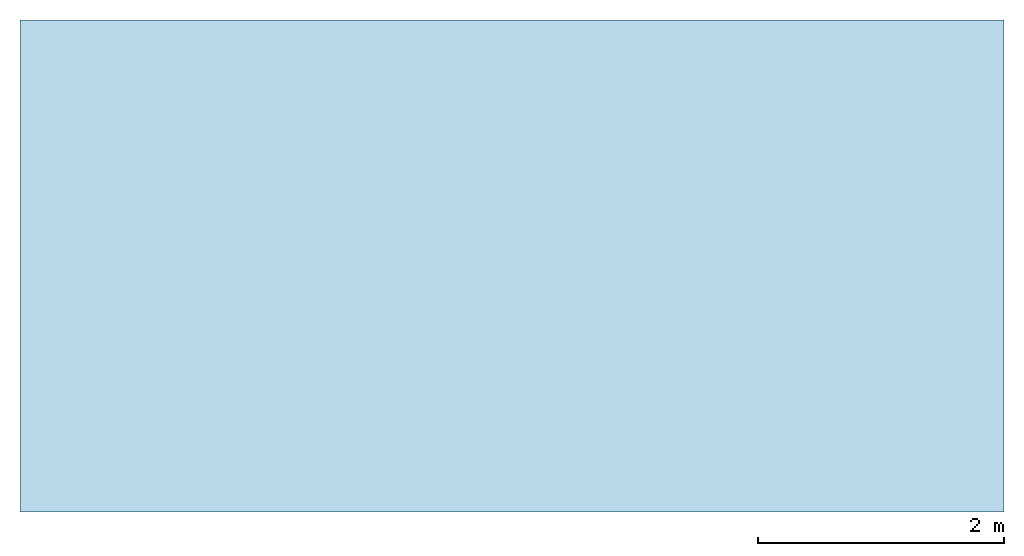
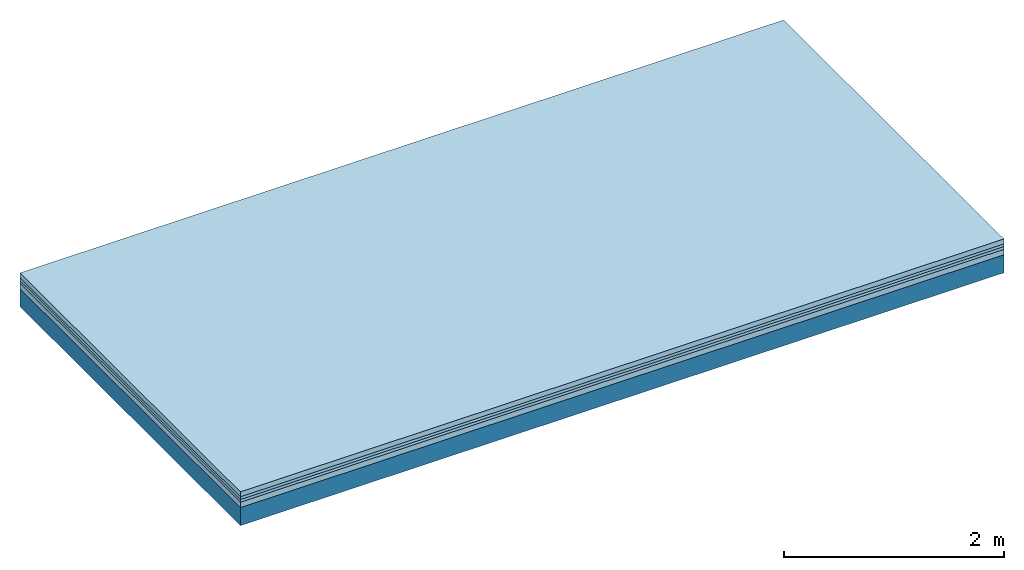
# One storey: 4 plates, 1 member, 1 element without a shape of its own.
"""IFC4 building model written with IfcOpenShell, lengths in metres."""

from ifc_helpers import new_model, si_unit, derived_unit, direction, frame, frame_2d, origin, origin_with_axes, place, context, project, spatial, rectangle, extrude, material, layer, layer_set, type_object, element, aggregate, save


model = new_model("IFC4")

# Units and contexts
plan_context = context("Plan", 3, precision=1e-05, world=origin(), true_north=direction((0.0, 1.0)))
model_context = context("Model", 3, precision=1e-05, world=origin(), true_north=direction((0.0, 1.0)))
ifc_project = project(units=[si_unit("LENGTHUNIT", "METRE"), derived_unit("SOUNDPRESSUREUNIT", [(si_unit("PRESSUREUNIT", "PASCAL", prefix="MICRO"), 0)]), si_unit("ENERGYUNIT", "JOULE", prefix="MEGA"), si_unit("MASSUNIT", "GRAM", prefix="KILO"), derived_unit("THERMALTRANSMITTANCEUNIT", [(si_unit("POWERUNIT", "WATT"), 1), (si_unit("AREAUNIT", "SQUARE_METRE"), -1), (si_unit("THERMODYNAMICTEMPERATUREUNIT", "KELVIN"), -1)]), derived_unit("AREADENSITYUNIT", [(si_unit("MASSUNIT", "GRAM", prefix="KILO"), 1), (si_unit("AREAUNIT", "SQUARE_METRE"), -1)]), derived_unit("USERDEFINED", [(si_unit("ENERGYUNIT", "JOULE", prefix="MEGA"), 1), (si_unit("AREAUNIT", "SQUARE_METRE"), -1)])], contexts=[plan_context, model_context])

# Site, building, storey
site = spatial("IfcSite", under=ifc_project)
building_placement = place(None, origin())
building = spatial("IfcBuilding", under=site, at=building_placement)
storey_placement = place(building_placement, origin())
storey = spatial("IfcBuildingStorey", under=building, at=storey_placement)

# Slab, member, plates
ifc_material_1 = material(Category="04.005")
ifc_layer_1 = layer(ifc_material_1, 0.055, Name="On-material")
ifc_material_2 = material()
ifc_layer_2 = layer(ifc_material_2, 0.03, Name="Impact sound insulation")
ifc_material_3 = material()
ifc_layer_3 = layer(ifc_material_3, 0.03, Name="Additional insulation")
ifc_material_4 = material(Category="03.011")
ifc_layer_4 = layer(ifc_material_4, 0.06, Name="on Supporting structure")
ifc_layer_5 = layer(None, 0.2, Name="Supporting structure")
ifc_layer_set = layer_set([ifc_layer_1, ifc_layer_2, ifc_layer_3, ifc_layer_4, ifc_layer_5])
slab_type = type_object("IfcSlabType", Name="A1089", PredefinedType="NOTDEFINED", material=ifc_layer_set)
slab_placement = place(None, frame((0.0, 0.0, 0.0), z_axis=(0.0, 0.0, -1.0), x_axis=(1.0, 0.0, 0.0)))
slab = element("IfcSlab", 1, at=slab_placement, inside=storey, type_object=slab_type, material=ifc_layer_set, Name="Slab #1")
ifc_material_5 = material()
member_placement = place(slab_placement, origin())
member = element("IfcMember", 2, at=member_placement, material=ifc_material_5, Name="Supporting structure", context=plan_context, shape_type="SweptSolid", body=[
    extrude(rectangle(XDim=1.0, YDim=0.2, at=frame_2d((0.5, 0.1), x_axis=(1.0, 0.0))), frame((0.0, 4.0, 0.175), z_axis=(0.0, -1.0, 0.0), x_axis=(1.0, 0.0, 0.0)), (0.0, 0.0, 1.0), 4.0),
    extrude(rectangle(XDim=1.0, YDim=0.2, at=frame_2d((0.5, 0.1), x_axis=(1.0, 0.0))), frame((1.0, 4.0, 0.175), z_axis=(0.0, -1.0, 0.0), x_axis=(1.0, 0.0, 0.0)), (0.0, 0.0, 1.0), 4.0),
    extrude(rectangle(XDim=1.0, YDim=0.2, at=frame_2d((0.5, 0.1), x_axis=(1.0, 0.0))), frame((2.0, 4.0, 0.175), z_axis=(0.0, -1.0, 0.0), x_axis=(1.0, 0.0, 0.0)), (0.0, 0.0, 1.0), 4.0),
    extrude(rectangle(XDim=1.0, YDim=0.2, at=frame_2d((0.5, 0.1), x_axis=(1.0, 0.0))), frame((3.0, 4.0, 0.175), z_axis=(0.0, -1.0, 0.0), x_axis=(1.0, 0.0, 0.0)), (0.0, 0.0, 1.0), 4.0),
    extrude(rectangle(XDim=1.0, YDim=0.2, at=frame_2d((0.5, 0.1), x_axis=(1.0, 0.0))), frame((4.0, 4.0, 0.175), z_axis=(0.0, -1.0, 0.0), x_axis=(1.0, 0.0, 0.0)), (0.0, 0.0, 1.0), 4.0),
    extrude(rectangle(XDim=1.0, YDim=0.2, at=frame_2d((0.5, 0.1), x_axis=(1.0, 0.0))), frame((5.0, 4.0, 0.175), z_axis=(0.0, -1.0, 0.0), x_axis=(1.0, 0.0, 0.0)), (0.0, 0.0, 1.0), 4.0),
    extrude(rectangle(XDim=1.0, YDim=0.2, at=frame_2d((0.5, 0.1), x_axis=(1.0, 0.0))), frame((6.0, 4.0, 0.175), z_axis=(0.0, -1.0, 0.0), x_axis=(1.0, 0.0, 0.0)), (0.0, 0.0, 1.0), 4.0),
    extrude(rectangle(XDim=1.0, YDim=0.2, at=frame_2d((0.5, 0.1), x_axis=(1.0, 0.0))), frame((7.0, 4.0, 0.175), z_axis=(0.0, -1.0, 0.0), x_axis=(1.0, 0.0, 0.0)), (0.0, 0.0, 1.0), 4.0),
])
plate_1_placement = place(slab_placement, origin())
plate_1 = element("IfcPlate", 3, at=plate_1_placement, material=ifc_material_1, Name="On-material", context=plan_context, shape_type="SweptSolid", body=[
    extrude(rectangle(XDim=8.0, YDim=4.0, at=frame_2d((4.0, 2.0), x_axis=(1.0, 0.0))), origin_with_axes(), (0.0, 0.0, 1.0), 0.055),
])
plate_2_placement = place(slab_placement, origin())
plate_2 = element("IfcPlate", 4, at=plate_2_placement, material=ifc_material_2, Name="Impact sound insulation", context=plan_context, shape_type="SweptSolid", body=[
    extrude(rectangle(XDim=8.0, YDim=4.0, at=frame_2d((4.0, 2.0), x_axis=(1.0, 0.0))), frame((0.0, 0.0, 0.055), z_axis=(0.0, 0.0, 1.0), x_axis=(1.0, 0.0, 0.0)), (0.0, 0.0, 1.0), 0.03),
])
plate_3_placement = place(slab_placement, origin())
plate_3 = element("IfcPlate", 5, at=plate_3_placement, material=ifc_material_3, Name="Additional insulation", context=plan_context, shape_type="SweptSolid", body=[
    extrude(rectangle(XDim=8.0, YDim=4.0, at=frame_2d((4.0, 2.0), x_axis=(1.0, 0.0))), frame((0.0, 0.0, 0.085), z_axis=(0.0, 0.0, 1.0), x_axis=(1.0, 0.0, 0.0)), (0.0, 0.0, 1.0), 0.03),
])
plate_4_placement = place(slab_placement, origin())
plate_4 = element("IfcPlate", 6, at=plate_4_placement, material=ifc_material_4, Name="on Supporting structure", context=plan_context, shape_type="SweptSolid", body=[
    extrude(rectangle(XDim=8.0, YDim=4.0, at=frame_2d((4.0, 2.0), x_axis=(1.0, 0.0))), frame((0.0, 0.0, 0.115), z_axis=(0.0, 0.0, 1.0), x_axis=(1.0, 0.0, 0.0)), (0.0, 0.0, 1.0), 0.06),
])
aggregate(slab, [plate_1, plate_2, plate_3, plate_4, member])

save(model, "model.ifc")
